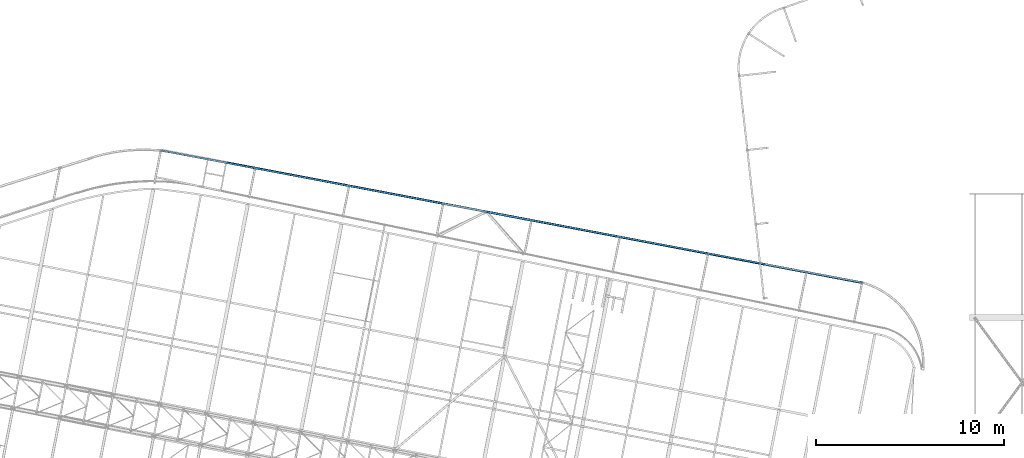
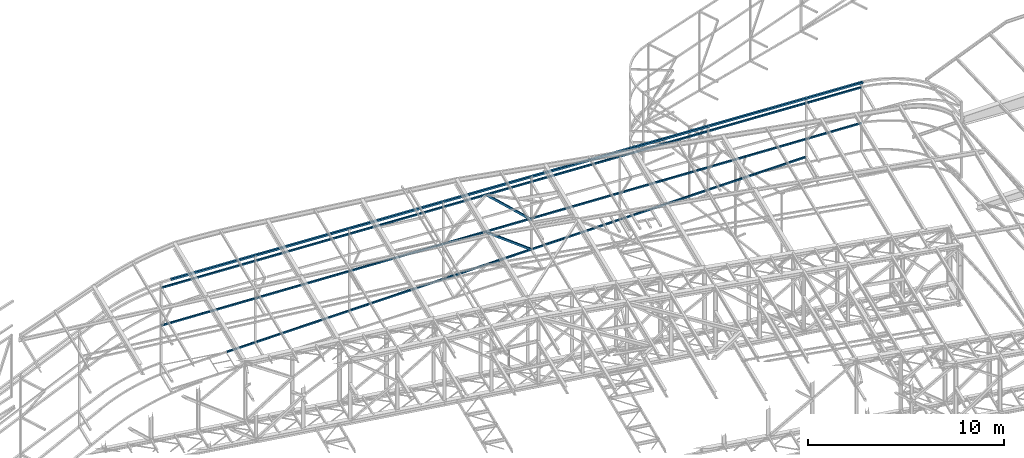
# One storey, part 97 of 215: 4 beams, 2 members, 6 elements without a shape of their own.
"""IFC2X3 building model written with IfcOpenShell, lengths in millimetres."""

from ifc_helpers import new_model, si_unit, frame, origin_with_axes, origin_2d_with_axis, place, context, subcontext, project, spatial, hollow_rectangle, extrude, material, type_object, element, aggregate, save


model = new_model("IFC2X3")

# Units and contexts
model_context = context("Model", 3, precision=1e-05, world=origin_with_axes())
body_context = subcontext(model_context, "Body", "Model", "MODEL_VIEW")
ifc_project = project(units=[si_unit("LENGTHUNIT", "METRE", prefix="MILLI"), si_unit("AREAUNIT", "SQUARE_METRE"), si_unit("VOLUMEUNIT", "CUBIC_METRE"), si_unit("MASSUNIT", "GRAM", prefix="KILO"), si_unit("TIMEUNIT", "SECOND"), si_unit("PLANEANGLEUNIT", "RADIAN"), si_unit("SOLIDANGLEUNIT", "STERADIAN"), si_unit("THERMODYNAMICTEMPERATUREUNIT", "DEGREE_CELSIUS"), si_unit("LUMINOUSINTENSITYUNIT", "LUMEN")], contexts=[model_context])

# Site, building, storey
site_placement = place(None, origin_with_axes())
site = spatial("IfcSite", under=ifc_project, at=site_placement, CompositionType="ELEMENT")
building_placement = place(site_placement, origin_with_axes())
building = spatial("IfcBuilding", under=site, at=building_placement, Name="Undefined", CompositionType="ELEMENT")
storey_placement = place(building_placement, origin_with_axes())
storey = spatial("IfcBuildingStorey", under=building, at=storey_placement, Name="Undefined", CompositionType="ELEMENT", Elevation=0.0)

# Assembly, beam
assembly_1_placement = place(storey_placement, origin_with_axes())
assembly_1 = element("IfcElementAssembly", 1, at=assembly_1_placement, inside=storey, Name="Steel Assembly", AssemblyPlace="NOTDEFINED", PredefinedType="RIGID_FRAME")
ifc_material_1 = material(Name="STEEL/S275JR")
beam_type_1 = type_object("IfcBeamType", PredefinedType="NOTDEFINED")
beam_1_placement = place(assembly_1_placement, frame((61381.8521543789, 64483.0964425889, 8581.33186436984), z_axis=(-0.187563580934887, -0.98209885665905, 0.0173706319939697), x_axis=(0.977958414029133, -0.185062630005513, 0.0966910720028804)))
beam_1 = element("IfcBeam", 2, at=beam_1_placement, type_object=beam_type_1, material=ifc_material_1, Name="LISSE", context=body_context, shape_type="SweptSolid", body=[
    extrude(hollow_rectangle(XDim=120.0, YDim=120.0, WallThickness=4.0, InnerFilletRadius=4.0, OuterFilletRadius=8.0, at=origin_2d_with_axis()), frame((37657.2606497113, 2.34158887626611e-12, -5.14433855959001e-13), z_axis=(-1.0, 0.0, 0.0), x_axis=(-6.93889390390723e-18, -1.0, -3.46944695195361e-18)), (0.0, 0.0, 1.0), 37657.3),
])
aggregate(assembly_1, [beam_1])

assembly_2_placement = place(storey_placement, origin_with_axes())
assembly_2 = element("IfcElementAssembly", 3, at=assembly_2_placement, inside=storey, Name="Steel Assembly", AssemblyPlace="NOTDEFINED", PredefinedType="RIGID_FRAME")
beam_type_2 = type_object("IfcBeamType", PredefinedType="NOTDEFINED")
beam_2_placement = place(assembly_2_placement, frame((64366.7606241658, 63905.815279728, 3366.01879475293), z_axis=(0.185059002917875, 0.982727411563879, 0.0), x_axis=(0.970975106212946, -0.182845907040102, 0.154190523033816)))
beam_2 = element("IfcBeam", 4, at=beam_2_placement, type_object=beam_type_2, material=ifc_material_1, Name="LISSE", context=body_context, shape_type="SweptSolid", body=[
    extrude(hollow_rectangle(XDim=100.0, YDim=100.0, WallThickness=5.0, InnerFilletRadius=5.0, OuterFilletRadius=10.0, at=origin_2d_with_axis()), frame((31720.1376368072, 8.80410678716559e-13, 3.67880824511828e-13), z_axis=(-1.0, 0.0, 0.0), x_axis=(-6.93889390390723e-18, -1.0, -3.46944695195361e-18)), (0.0, 0.0, 1.0), 31720.1),
])
aggregate(assembly_2, [beam_2])

assembly_3_placement = place(storey_placement, origin_with_axes())
assembly_3 = element("IfcElementAssembly", 5, at=assembly_3_placement, inside=storey, Name="Steel Assembly", AssemblyPlace="NOTDEFINED", PredefinedType="RIGID_FRAME")
beam_3_placement = place(assembly_3_placement, frame((60861.1065961107, 64565.9707128503, 5833.71692560583), z_axis=(0.185059002917875, 0.982727411563879, 0.0), x_axis=(0.977725544786686, -0.18411709295983, 0.100765346978016)))
beam_3 = element("IfcBeam", 6, at=beam_3_placement, type_object=beam_type_2, material=ifc_material_1, Name="LISSE", context=body_context, shape_type="SweptSolid", body=[
    extrude(hollow_rectangle(XDim=100.0, YDim=100.0, WallThickness=5.0, InnerFilletRadius=5.0, OuterFilletRadius=10.0, at=origin_2d_with_axis()), frame((38143.4765990552, -1.36424205265939e-12, -2.86610819137131e-11), z_axis=(-1.0, 0.0, 0.0), x_axis=(-6.93889390390723e-18, -1.0, -3.46944695195361e-18)), (0.0, 0.0, 1.0), 38143.5),
])
aggregate(assembly_3, [beam_3])

assembly_4_placement = place(storey_placement, origin_with_axes())
assembly_4 = element("IfcElementAssembly", 7, at=assembly_4_placement, inside=storey, Name="Steel Assembly", AssemblyPlace="NOTDEFINED", PredefinedType="RIGID_FRAME")
beam_4_placement = place(assembly_4_placement, frame((60866.8317952465, 64564.8920086296, 8189.14295205715), z_axis=(0.185060101913985, 0.982727204543219, -1.14129999948702e-05), x_axis=(0.978037774657659, -0.184175888935533, 0.0975774219658451)))
beam_4 = element("IfcBeam", 8, at=beam_4_placement, type_object=beam_type_2, material=ifc_material_1, Name="LISSE", context=body_context, shape_type="SweptSolid", body=[
    extrude(hollow_rectangle(XDim=100.0, YDim=100.0, WallThickness=5.0, InnerFilletRadius=5.0, OuterFilletRadius=10.0, at=origin_2d_with_axis()), frame((38131.2996350982, -1.43867278694501e-12, -9.22605713070107e-14), z_axis=(-1.0, 0.0, 0.0), x_axis=(-6.93889390390723e-18, -1.0, -3.46944695195361e-18)), (0.0, 0.0, 1.0), 38131.3),
])
aggregate(assembly_4, [beam_4])

# Assembly, member
assembly_5_placement = place(storey_placement, origin_with_axes())
assembly_5 = element("IfcElementAssembly", 9, at=assembly_5_placement, inside=storey, Name="Steel Assembly", AssemblyPlace="NOTDEFINED", PredefinedType="RIGID_FRAME")
ifc_material_2 = material(Name="STEEL/S235JR")
member_type = type_object("IfcMemberType", PredefinedType="NOTDEFINED")
member_1_placement = place(assembly_5_placement, frame((80570.8833045233, 60843.1262086005, 7799.11627406862), z_axis=(0.642739672323484, -0.121035357060917, 0.756462924380724), x_axis=(-0.742759360962142, 0.143351647992693, 0.654032748966663)))
member_1 = element("IfcMember", 10, at=member_1_placement, type_object=member_type, material=ifc_material_2, context=body_context, shape_type="SweptSolid", body=[
    extrude(hollow_rectangle(XDim=120.0, YDim=120.0, WallThickness=5.0, InnerFilletRadius=5.0, OuterFilletRadius=10.0, at=origin_2d_with_axis()), frame((3235.47938778364, 2.1749065443856e-14, -1.79605185600875e-13), z_axis=(-1.0, 0.0, 0.0), x_axis=(-6.93889390390723e-18, -1.0, -3.46944695195361e-18)), (0.0, 0.0, 1.0), 3235.5),
])
aggregate(assembly_5, [member_1])

assembly_6_placement = place(storey_placement, origin_with_axes())
assembly_6 = element("IfcElementAssembly", 11, at=assembly_6_placement, inside=storey, Name="Steel Assembly", AssemblyPlace="NOTDEFINED", PredefinedType="RIGID_FRAME")
member_2_placement = place(assembly_6_placement, frame((80570.8851548018, 60843.1360836095, 5935.34725879383), z_axis=(0.548440704914448, -0.105875516983485, 0.82945956387061), x_axis=(-0.814422582604555, 0.157222851923661, 0.558566765728787)))
member_2 = element("IfcMember", 12, at=member_2_placement, type_object=member_type, material=ifc_material_2, context=body_context, shape_type="SweptSolid", body=[
    extrude(hollow_rectangle(XDim=120.0, YDim=120.0, WallThickness=5.0, InnerFilletRadius=5.0, OuterFilletRadius=10.0, at=origin_2d_with_axis()), frame((2917.36820448174, -5.73845553677367e-14, 0.0), z_axis=(-1.0, 0.0, 0.0), x_axis=(-6.93889390390723e-18, -1.0, -3.46944695195361e-18)), (0.0, 0.0, 1.0), 2917.4),
])
aggregate(assembly_6, [member_2])

save(model, "model.ifc")
